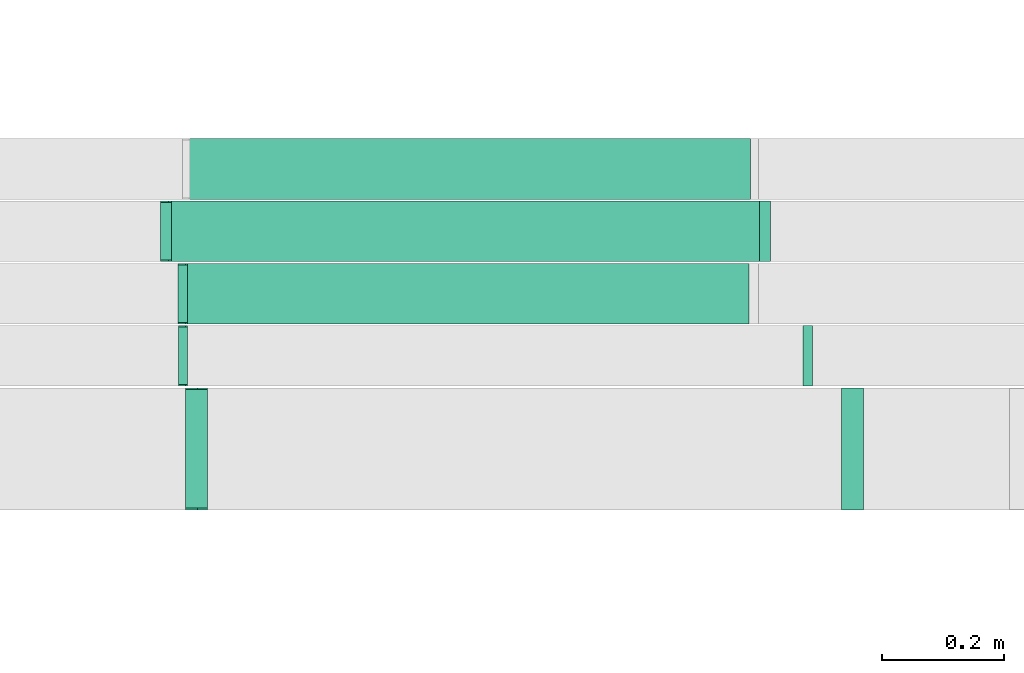
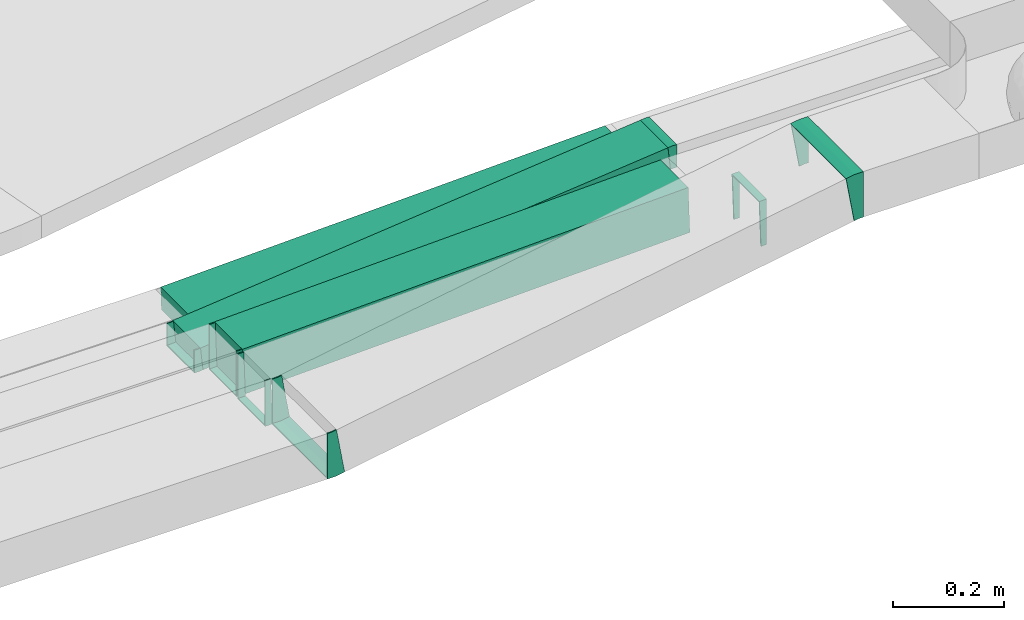
# One storey, part 12 of 38: 7 flow fittings, 3 flow segments.
"""IFC2X3 building model written with IfcOpenShell, lengths in millimetres."""

from ifc_helpers import new_model, entity, si_unit, converted_unit, derived_unit, direction, frame, frame_2d, origin, origin_2d_with_axis, place, context, subcontext, project, spatial, rectangle, extrude, faceted_brep, source, transform, mapped, material, type_object, type_shapes, element, save


model = new_model("IFC2X3")

# Units and contexts
model_context = context("Model", 3, precision=0.01, world=origin(), true_north=direction((6.12303176911189e-17, 1.0)))
body_context = subcontext(model_context, "Body", "Model", "MODEL_VIEW")
ifc_project = project(units=[si_unit("LENGTHUNIT", "METRE", prefix="MILLI"), si_unit("AREAUNIT", "SQUARE_METRE"), si_unit("VOLUMEUNIT", "CUBIC_METRE"), converted_unit("PLANEANGLEUNIT", "DEGREE", entity("IfcRatioMeasure", 0.0174532925199433), si_unit("PLANEANGLEUNIT", "RADIAN"), dimensions=[0, 0, 0, 0, 0, 0, 0]), si_unit("MASSUNIT", "GRAM", prefix="KILO"), derived_unit("MASSDENSITYUNIT", [(si_unit("MASSUNIT", "GRAM", prefix="KILO"), 1), (si_unit("LENGTHUNIT", "METRE"), -3)]), derived_unit("MOMENTOFINERTIAUNIT", [(si_unit("LENGTHUNIT", "METRE"), 4)]), si_unit("TIMEUNIT", "SECOND"), si_unit("FREQUENCYUNIT", "HERTZ"), si_unit("THERMODYNAMICTEMPERATUREUNIT", "DEGREE_CELSIUS"), derived_unit("THERMALTRANSMITTANCEUNIT", [(si_unit("MASSUNIT", "GRAM", prefix="KILO"), 1), (si_unit("THERMODYNAMICTEMPERATUREUNIT", "KELVIN"), -1), (si_unit("TIMEUNIT", "SECOND"), -3)]), derived_unit("VOLUMETRICFLOWRATEUNIT", [(si_unit("LENGTHUNIT", "METRE"), 3), (si_unit("TIMEUNIT", "SECOND"), -1)]), derived_unit("MASSFLOWRATEUNIT", [(si_unit("MASSUNIT", "GRAM", prefix="KILO"), 1), (si_unit("TIMEUNIT", "SECOND"), -1)]), derived_unit("ROTATIONALFREQUENCYUNIT", [(si_unit("TIMEUNIT", "SECOND"), -1)]), si_unit("ELECTRICCURRENTUNIT", "AMPERE"), si_unit("ELECTRICVOLTAGEUNIT", "VOLT"), si_unit("POWERUNIT", "WATT"), si_unit("FORCEUNIT", "NEWTON", prefix="KILO"), si_unit("ILLUMINANCEUNIT", "LUX"), si_unit("LUMINOUSFLUXUNIT", "LUMEN"), si_unit("LUMINOUSINTENSITYUNIT", "CANDELA"), derived_unit("USERDEFINED", [(si_unit("MASSUNIT", "GRAM", prefix="KILO"), -1), (si_unit("LENGTHUNIT", "METRE"), -2), (si_unit("TIMEUNIT", "SECOND"), 3), (si_unit("LUMINOUSFLUXUNIT", "LUMEN"), 1)]), derived_unit("LINEARVELOCITYUNIT", [(si_unit("LENGTHUNIT", "METRE"), 1), (si_unit("TIMEUNIT", "SECOND"), -1)]), si_unit("PRESSUREUNIT", "PASCAL"), derived_unit("USERDEFINED", [(si_unit("LENGTHUNIT", "METRE"), -2), (si_unit("MASSUNIT", "GRAM", prefix="KILO"), 1), (si_unit("TIMEUNIT", "SECOND"), -2)]), derived_unit("LINEARFORCEUNIT", [(si_unit("MASSUNIT", "GRAM", prefix="KILO"), 1), (si_unit("LENGTHUNIT", "METRE"), 1), (si_unit("TIMEUNIT", "SECOND"), -2), (si_unit("LENGTHUNIT", "METRE"), -1)]), derived_unit("PLANARFORCEUNIT", [(si_unit("MASSUNIT", "GRAM", prefix="KILO"), 1), (si_unit("LENGTHUNIT", "METRE"), 1), (si_unit("TIMEUNIT", "SECOND"), -2), (si_unit("LENGTHUNIT", "METRE"), -2)])], contexts=[model_context])

# Site, building, storey
site_placement = place(None, frame((0.0, -0.00077364408347762, 0.0)))
site = spatial("IfcSite", under=ifc_project, at=site_placement, CompositionType="ELEMENT")
building_placement = place(site_placement, origin())
building = spatial("IfcBuilding", under=site, at=building_placement, CompositionType="ELEMENT")
storey_placement = place(building_placement, frame((0.0, 0.0, 4200.0)))
storey = spatial("IfcBuildingStorey", under=building, at=storey_placement, CompositionType="ELEMENT", Elevation=4200.0)

# Flow segments
cable_carrier_segment_type = type_object("IfcCableCarrierSegmentType", PredefinedType="CABLETRAYSEGMENT")
flow_segment_1_placement = place(storey_placement, frame((12998.9012277775, 11748.9581146252, 2718.65733192917)))
element("IfcFlowSegment", 1, at=flow_segment_1_placement, inside=storey, type_object=cable_carrier_segment_type, context=body_context, shape_type="SweptSolid", body=[
    extrude(rectangle(XDim=99.9999999999996, YDim=99.9999999999989, at=frame_2d((0.0, 0.0), x_axis=(0.0, 1.0))), frame((1.68886490402337, 50.0, 49.9714692133015), z_axis=(0.999429384266034, 0.0, 0.0337772980804675), x_axis=(0.0, 1.0, 0.0)), (0.0, 0.0, 1.0), 927.191396822279),
])
flow_segment_2_placement = place(storey_placement, frame((12971.088655895, 11851.5299176424, 2719.33222054804)))
element("IfcFlowSegment", 2, at=flow_segment_2_placement, inside=storey, type_object=cable_carrier_segment_type, context=body_context, shape_type="SweptSolid", body=[
    extrude(rectangle(XDim=50.0000000000007, YDim=99.9999999999989, at=frame_2d((0.0, 0.0), x_axis=(0.0, 1.0))), frame((2.5594046422675, 50.0, 24.8686438688795), z_axis=(0.994745754755165, 0.0, 0.102376185690699), x_axis=(0.0, 1.0, 0.0)), (0.0, 0.0, 1.0), 976.772776710934),
])
flow_segment_3_placement = place(storey_placement, frame((13004.949762973, 11954.0299176424, 2718.61453574912)))
element("IfcFlowSegment", 3, at=flow_segment_3_placement, inside=storey, type_object=cable_carrier_segment_type, context=body_context, shape_type="SweptSolid", body=[
    extrude(rectangle(XDim=50.0000000000009, YDim=99.9999999999989, at=origin_2d_with_axis()), frame((0.844432452017099, 50.0, 24.9857346066513), z_axis=(0.999429384266034, 0.0, 0.0337772980804668), x_axis=(-0.0337772980804668, 0.0, 0.999429384266034)), (0.0, 0.0, 1.0), 923.681320339212),
])

# Flow fittings
ifc_material = material()
cable_carrier_fitting_type_1 = type_object("IfcCableCarrierFittingType", PredefinedType="NOTDEFINED", material=ifc_material)
shared_shape_1 = source(origin(), body_context, "Body", "Brep", [
    faceted_brep([(-13.9062982663145, -50.0, 100.0), (-13.9062982663142, 50.0, 100.0), (-13.9062982663142, 50.0, 97.4600000101635), (-13.9062982663145, -47.4600000101599, 97.4600000101635), (-13.9062982663145, -47.4600000101599, -97.4600000101564), (-13.9062982663142, 50.0, -97.4600000101564), (-13.9062982663142, 50.0, -100.0), (-13.9062982663145, -50.0, -100.0), (22.1292204448822, -46.9433992588264, 100.0), (22.1292204448822, -46.9433992588264, -100.0), (5.28602541809911, 51.6279291348285, -100.0), (5.28602541809911, 51.6279291348285, -97.4600000101564), (21.7014032929131, -44.4396875276424, -97.4600000101565), (21.7014032929131, -44.4396875276424, 97.4600000101635), (5.28602541809911, 51.6279291348285, 97.4600000101635), (5.2860254180991, 51.6279291348285, 100.0), (4.24109441253112, -50.0, 100.0), (-4.24109441253036, 50.0, 100.0), (-4.24109441253036, 50.0, 97.4600000101635), (4.02564681723631, -47.46000001016, 97.4600000101635), (4.02564681723631, -47.46000001016, -97.4600000101564), (-4.24109441253036, 50.0, -97.4600000101564), (-4.24109441253036, 50.0, -100.0), (4.24109441253108, -50.0, -100.0)], [[[0, 1, 2, 3, 4, 5, 6, 7]], [[8, 9, 10, 11, 12, 13, 14, 15]], [[1, 0, 16, 8, 15, 17]], [[2, 1, 17, 18]], [[3, 2, 18, 14, 13, 19]], [[4, 3, 19, 20]], [[5, 4, 20, 12, 11, 21]], [[6, 5, 21, 22]], [[7, 6, 22, 10, 9, 23]], [[0, 7, 23, 16]], [[18, 17, 15, 14]], [[20, 19, 13, 12]], [[22, 21, 11, 10]], [[16, 23, 9, 8]]]),
])
type_shapes(cable_carrier_fitting_type_1, [shared_shape_1])
for number, where, z_axis, x_axis in (
    (4, (14099.5279873927, 11543.7857236441, 2954.05791329438), (0.0, -1.0, 0.0), (-1.0, 0.0, 0.0)),
    (5, (13013.1748604001, 11543.7857236441, 2768.42931434907), (0.0, 1.0, 0.0), (-0.98571328393655, 0.0, -0.168431950267824)),
):
    element("IfcFlowFitting", number, at=place(storey_placement, frame(where, z_axis=z_axis, x_axis=x_axis)), inside=storey, type_object=cable_carrier_fitting_type_1, material=ifc_material, context=body_context, shape_type="MappedRepresentation", body=[
        mapped(shared_shape_1, transform((0.0, 0.0, 0.0), scale=1.0)),
    ])
cable_carrier_fitting_type_2 = type_object("IfcCableCarrierFittingType", PredefinedType="NOTDEFINED", material=ifc_material)
shared_shape_2 = source(origin(), body_context, "Body", "Brep", [
    faceted_brep([(-6.77381423238034, -50.0, 50.0), (-6.77381423238001, 50.0, 50.0), (-6.77381423238001, 50.0, 47.4600000101635), (-6.77381423238033, -47.46000001016, 47.4600000101635), (-6.77381423238033, -47.46000001016, -47.4600000101565), (-6.77381423238001, 50.0, -47.4600000101565), (-6.77381423238001, 50.0, -50.0), (-6.77381423238034, -50.0, -50.0), (8.45881389142528, -49.7426680708332, 50.0), (8.45881389142528, -49.7426680708332, -50.0), (5.08108408337666, 50.2002703557701, -50.0), (5.08108408337666, 50.2002703557701, -47.4600000101565), (8.37301955464403, -47.2041174449516, -47.4600000101565), (8.37301955464403, -47.2041174449517, 47.4600000101635), (5.08108408337666, 50.2002703557701, 47.4600000101635), (5.08108408337666, 50.2002703557702, 50.0), (0.844673443991129, -50.0, 50.0), (-0.844673443990412, 50.0, 50.0), (-0.844673443990412, 50.0, 47.4600000101635), (0.801764033208029, -47.46000001016, 47.4600000101635), (0.801764033208029, -47.46000001016, -47.4600000101565), (-0.844673443990412, 50.0, -47.4600000101565), (-0.844673443990412, 50.0, -50.0), (0.844673443991122, -50.0, -50.0)], [[[0, 1, 2, 3, 4, 5, 6, 7]], [[8, 9, 10, 11, 12, 13, 14, 15]], [[1, 0, 16, 8, 15, 17]], [[2, 1, 17, 18]], [[3, 2, 18, 14, 13, 19]], [[4, 3, 19, 20]], [[5, 4, 20, 12, 11, 21]], [[6, 5, 21, 22]], [[7, 6, 22, 10, 9, 23]], [[0, 7, 23, 16]], [[18, 17, 15, 14]], [[20, 19, 13, 12]], [[22, 21, 11, 10]], [[16, 23, 9, 8]]]),
])
type_shapes(cable_carrier_fitting_type_2, [shared_shape_2])
for number, where, z_axis, x_axis in (
    (6, (12994.0349464158, 11696.8541189971, 2765.22575139994), (0.0, -1.0, 0.0), (1.0, 0.0, 0.0)),
    (7, (14022.9628903814, 11696.8541189971, 2800.0), (0.0, -1.0, 0.0), (-1.0, 0.0, 0.0)),
    (8, (12993.8201436942, 11798.9581146253, 2768.4), (0.0, -1.0, 0.0), (1.0, 0.0, 0.0)),
):
    element("IfcFlowFitting", number, at=place(storey_placement, frame(where, z_axis=z_axis, x_axis=x_axis)), inside=storey, type_object=cable_carrier_fitting_type_2, material=ifc_material, context=body_context, shape_type="MappedRepresentation", body=[
        mapped(shared_shape_2, transform((0.0, 0.0, 0.0), scale=1.0)),
    ])
cable_carrier_fitting_type_3 = type_object("IfcCableCarrierFittingType", PredefinedType="NOTDEFINED", material=ifc_material)
shared_shape_3 = source(origin(), body_context, "Body", "Brep", [
    faceted_brep([(-7.82276084536892, -25.0, 50.0), (-7.82276084536876, 25.0, 50.0), (-7.82276084536876, 25.0, 47.4600000101635), (-7.82276084536892, -22.46000001016, 47.4600000101635), (-7.82276084536892, -22.46000001016, -47.4600000101565), (-7.82276084536876, 25.0, -47.4600000101565), (-7.82276084536876, 25.0, -50.0), (-7.82276084536892, -25.0, -50.0), (10.3410627836642, -24.06777945196, 50.0), (10.3410627836642, -24.06777945196, -50.0), (5.22225349912846, 25.6695082857982, -50.0), (5.22225349912846, 25.6695082857982, -47.4600000101565), (10.08102727305, -21.5411252449885, -47.4600000101565), (10.08102727305, -21.5411252449885, 47.4600000101635), (5.22225349912846, 25.6695082857982, 47.4600000101635), (5.22225349912846, 25.6695082857982, 50.0), (1.28307311153182, -25.0, 50.0), (-1.28307311153107, 25.0, 50.0), (-1.28307311153107, 25.0, 47.4600000101635), (1.15271288392164, -22.46000001016, 47.4600000101635), (1.15271288392164, -22.46000001016, -47.4600000101565), (-1.28307311153107, 25.0, -47.4600000101565), (-1.28307311153107, 25.0, -50.0), (1.28307311153179, -25.0, -50.0)], [[[0, 1, 2, 3, 4, 5, 6, 7]], [[8, 9, 10, 11, 12, 13, 14, 15]], [[1, 0, 16, 8, 15, 17]], [[2, 1, 17, 18]], [[3, 2, 18, 14, 13, 19]], [[4, 3, 19, 20]], [[5, 4, 20, 12, 11, 21]], [[6, 5, 21, 22]], [[7, 6, 22, 10, 9, 23]], [[0, 7, 23, 16]], [[18, 17, 15, 14]], [[20, 19, 13, 12]], [[22, 21, 11, 10]], [[16, 23, 9, 8]]]),
])
type_shapes(cable_carrier_fitting_type_3, [shared_shape_3])
for number, where, z_axis, x_axis in (
    (9, (13953.0702916723, 11901.5299176424, 2845.0), (0.0, -1.0, 0.0), (-1.0, 0.0, 0.0)),
    (10, (12965.866402396, 11901.5299176425, 2743.40000000001), (0.0, 1.0, 0.0), (-0.994745754755166, 0.0, -0.102376185690695)),
):
    element("IfcFlowFitting", number, at=place(storey_placement, frame(where, z_axis=z_axis, x_axis=x_axis)), inside=storey, type_object=cable_carrier_fitting_type_3, material=ifc_material, context=body_context, shape_type="MappedRepresentation", body=[
        mapped(shared_shape_3, transform((0.0, 0.0, 0.0), scale=1.0)),
    ])

save(model, "model.ifc")
